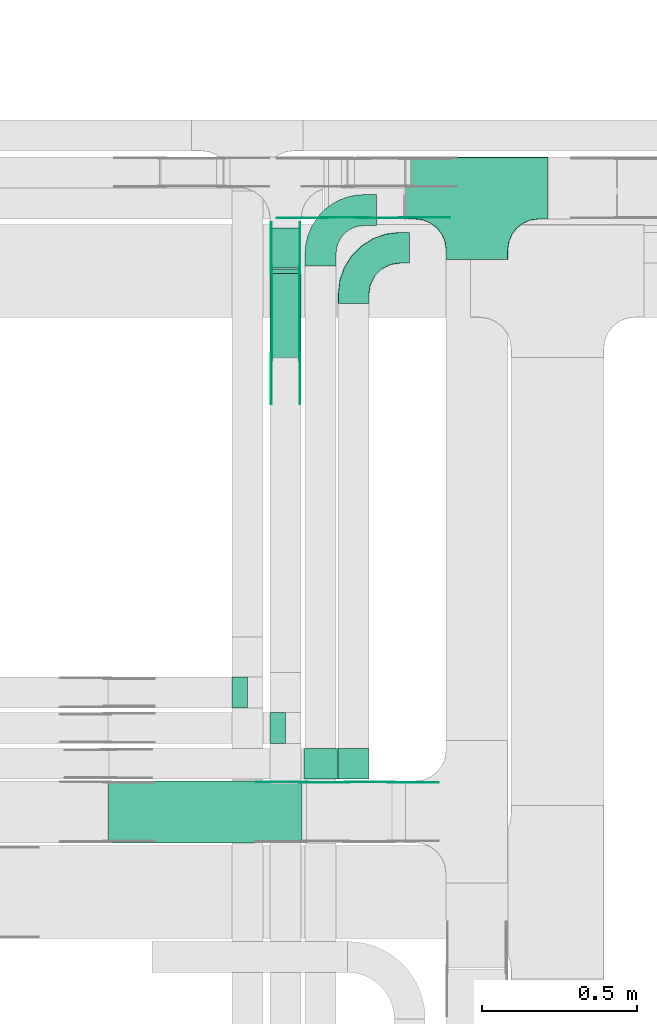
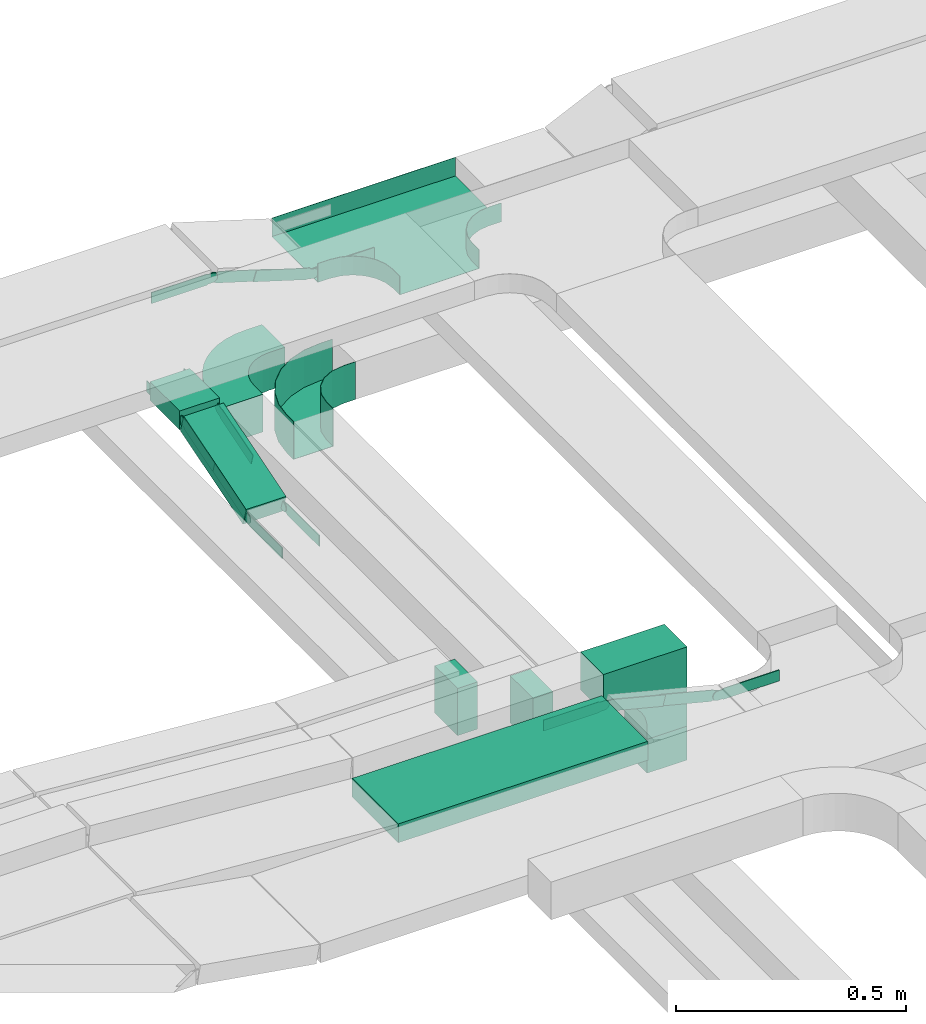
# One storey, part 6 of 19: 20 flow fittings, 6 flow segments.
"""IFC2X3 building model written with IfcOpenShell, lengths in millimetres."""

from ifc_helpers import new_model, entity, si_unit, converted_unit, derived_unit, direction, frame, frame_2d, origin, origin_2d_with_axis, place, context, subcontext, project, spatial, polyline, circle_curve, parameter, trimmed, segment, composite_curve, rectangle, outline, extrude, faceted_brep, source, transform, mapped, material, type_object, type_shapes, element, save


model = new_model("IFC2X3")

# Units and contexts
model_context = context("Model", 3, precision=0.01, world=origin(), true_north=direction((6.12303176911189e-17, 1.0)))
body_context = subcontext(model_context, "Body", "Model", "MODEL_VIEW")
ifc_project = project(units=[si_unit("LENGTHUNIT", "METRE", prefix="MILLI"), si_unit("AREAUNIT", "SQUARE_METRE"), si_unit("VOLUMEUNIT", "CUBIC_METRE"), converted_unit("PLANEANGLEUNIT", "DEGREE", entity("IfcRatioMeasure", 0.0174532925199433), si_unit("PLANEANGLEUNIT", "RADIAN"), dimensions=[0, 0, 0, 0, 0, 0, 0]), si_unit("MASSUNIT", "GRAM", prefix="KILO"), derived_unit("MASSDENSITYUNIT", [(si_unit("MASSUNIT", "GRAM", prefix="KILO"), 1), (si_unit("LENGTHUNIT", "METRE"), -3)]), derived_unit("MOMENTOFINERTIAUNIT", [(si_unit("LENGTHUNIT", "METRE"), 4)]), si_unit("TIMEUNIT", "SECOND"), si_unit("FREQUENCYUNIT", "HERTZ"), si_unit("THERMODYNAMICTEMPERATUREUNIT", "DEGREE_CELSIUS"), derived_unit("THERMALTRANSMITTANCEUNIT", [(si_unit("MASSUNIT", "GRAM", prefix="KILO"), 1), (si_unit("THERMODYNAMICTEMPERATUREUNIT", "KELVIN"), -1), (si_unit("TIMEUNIT", "SECOND"), -3)]), derived_unit("VOLUMETRICFLOWRATEUNIT", [(si_unit("LENGTHUNIT", "METRE"), 3), (si_unit("TIMEUNIT", "SECOND"), -1)]), derived_unit("MASSFLOWRATEUNIT", [(si_unit("MASSUNIT", "GRAM", prefix="KILO"), 1), (si_unit("TIMEUNIT", "SECOND"), -1)]), derived_unit("ROTATIONALFREQUENCYUNIT", [(si_unit("TIMEUNIT", "SECOND"), -1)]), si_unit("ELECTRICCURRENTUNIT", "AMPERE"), si_unit("ELECTRICVOLTAGEUNIT", "VOLT"), si_unit("POWERUNIT", "WATT"), si_unit("FORCEUNIT", "NEWTON", prefix="KILO"), si_unit("ILLUMINANCEUNIT", "LUX"), si_unit("LUMINOUSFLUXUNIT", "LUMEN"), si_unit("LUMINOUSINTENSITYUNIT", "CANDELA"), derived_unit("USERDEFINED", [(si_unit("MASSUNIT", "GRAM", prefix="KILO"), -1), (si_unit("LENGTHUNIT", "METRE"), -2), (si_unit("TIMEUNIT", "SECOND"), 3), (si_unit("LUMINOUSFLUXUNIT", "LUMEN"), 1)]), derived_unit("LINEARVELOCITYUNIT", [(si_unit("LENGTHUNIT", "METRE"), 1), (si_unit("TIMEUNIT", "SECOND"), -1)]), si_unit("PRESSUREUNIT", "PASCAL"), derived_unit("USERDEFINED", [(si_unit("LENGTHUNIT", "METRE"), -2), (si_unit("MASSUNIT", "GRAM", prefix="KILO"), 1), (si_unit("TIMEUNIT", "SECOND"), -2)]), derived_unit("LINEARFORCEUNIT", [(si_unit("MASSUNIT", "GRAM", prefix="KILO"), 1), (si_unit("LENGTHUNIT", "METRE"), 1), (si_unit("TIMEUNIT", "SECOND"), -2), (si_unit("LENGTHUNIT", "METRE"), -1)]), derived_unit("PLANARFORCEUNIT", [(si_unit("MASSUNIT", "GRAM", prefix="KILO"), 1), (si_unit("LENGTHUNIT", "METRE"), 1), (si_unit("TIMEUNIT", "SECOND"), -2), (si_unit("LENGTHUNIT", "METRE"), -2)])], contexts=[model_context])

# Site, building, storey
site_placement = place(None, frame((0.0, -0.00077364408347762, 0.0)))
site = spatial("IfcSite", under=ifc_project, at=site_placement, CompositionType="ELEMENT")
building_placement = place(site_placement, origin())
building = spatial("IfcBuilding", under=site, at=building_placement, CompositionType="ELEMENT")
storey_placement = place(building_placement, frame((0.0, 0.0, 12000.0)))
storey = spatial("IfcBuildingStorey", under=building, at=storey_placement, CompositionType="ELEMENT", Elevation=12000.0)

# Flow segments
cable_carrier_segment_type = type_object("IfcCableCarrierSegmentType", PredefinedType="CABLETRAYSEGMENT")
flow_segment_1_placement = place(storey_placement, frame((17450.8030725781, 14414.5228594546, 2586.13196287297)))
element("IfcFlowSegment", 1, at=flow_segment_1_placement, inside=storey, type_object=cable_carrier_segment_type, context=body_context, shape_type="SweptSolid", body=[
    extrude(rectangle(XDim=129.10701547123, YDim=99.9999999999989, at=frame_2d((1.08002495835535e-12, 0.0), x_axis=(1.0, 0.0))), frame((50.0, 64.5535077356138, 0.0), z_axis=(0.0, 0.0, 1.0), x_axis=(0.0, -1.0, 0.0)), (0.0, 0.0, 1.0), 50.0000000000016),
])
flow_segment_2_placement = place(storey_placement, frame((17327.7611527256, 12994.157206347, 2680.0)))
element("IfcFlowSegment", 2, at=flow_segment_2_placement, inside=storey, type_object=cable_carrier_segment_type, context=body_context, shape_type="SweptSolid", body=[
    extrude(rectangle(XDim=99.9999999999989, YDim=50.0000000000016, at=frame_2d((-2.16715534406831e-12, 2.16715534406831e-12), x_axis=(1.0, 0.0))), frame((25.0, 50.0, 0.0), z_axis=(0.0, 0.0, 1.0), x_axis=(0.0, 1.0, 0.0)), (0.0, 0.0, 1.0), 125.0),
])
flow_segment_3_placement = place(storey_placement, frame((17450.8030725781, 14125.2555366497, 2502.6519148827)))
element("IfcFlowSegment", 3, at=flow_segment_3_placement, inside=storey, type_object=cable_carrier_segment_type, context=body_context, shape_type="SweptSolid", body=[
    extrude(rectangle(XDim=49.9999999999967, YDim=283.929306322978, at=frame_2d((1.03739239420975e-12, -3.17967874252645e-13), x_axis=(0.0, 1.0))), frame((0.0, 143.070765615047, 65.4140665542328), z_axis=(1.0, 0.0, 0.0), x_axis=(0.0, -0.956304755963122, -0.292371704722454)), (0.0, 0.0, 1.0), 99.9999999999989),
])
flow_segment_4_placement = place(storey_placement, frame((17450.803072578, 12879.4401033081, 2680.0)))
element("IfcFlowSegment", 4, at=flow_segment_4_placement, inside=storey, type_object=cable_carrier_segment_type, context=body_context, shape_type="SweptSolid", body=[
    extrude(rectangle(XDim=99.9999999999989, YDim=50.0000000000016, at=frame_2d((0.0, -2.16715534406831e-12), x_axis=(1.0, 0.0))), frame((25.0, 50.0, 0.0), z_axis=(0.0, 0.0, 1.0), x_axis=(0.0, 1.0, 0.0)), (0.0, 0.0, 1.0), 125.0),
])
flow_segment_5_placement = place(storey_placement, frame((17670.2969319306, 12764.157206347, 2600.0)))
element("IfcFlowSegment", 5, at=flow_segment_5_placement, inside=storey, type_object=cable_carrier_segment_type, context=body_context, shape_type="SweptSolid", body=[
    extrude(rectangle(XDim=99.9999999999989, YDim=99.9999999999989, at=origin_2d_with_axis()), frame((50.0, 50.0, 0.0), z_axis=(0.0, 0.0, 1.0), x_axis=(-1.0, 0.0, 0.0)), (0.0, 0.0, 1.0), 90.000000000038),
])
flow_segment_6_placement = place(storey_placement, frame((16927.6135747369, 12558.7956510924, 2800.0)))
element("IfcFlowSegment", 6, at=flow_segment_6_placement, inside=storey, type_object=cable_carrier_segment_type, context=body_context, shape_type="SweptSolid", body=[
    extrude(rectangle(XDim=625.530791542038, YDim=199.999999999998, at=frame_2d((-1.08002495835535e-12, 0.0), x_axis=(1.0, 0.0))), frame((312.76539577102, 100.0, 0.0)), (0.0, 0.0, 1.0), 50.0000000000016),
])

# Flow fittings
ifc_material_1 = material(Name="G")
cable_carrier_fitting_type_1 = type_object("IfcCableCarrierFittingType", PredefinedType="NOTDEFINED", material=ifc_material_1)
shared_shape_1 = source(origin(), body_context, "Body", "SweptSolid", [
    extrude(outline(composite_curve([segment(trimmed(circle_curve(frame_2d((-44.5901162790698, 0.0), x_axis=(1.0, 0.0)), 12.5), [parameter(90.0000000000007)], [parameter(270.0)], True, "PARAMETER"), True, "CONTINUOUS"), segment(polyline([(-44.5901162790697, -12.5), (-33.0901162790698, -12.5)]), True, "CONTINUOUS"), segment(polyline([(-33.0901162790698, -12.5), (-31.2296511627907, -14.5)]), True, "CONTINUOUS"), segment(polyline([(-31.2296511627907, -14.5), (108.90988372093, -14.5)]), True, "CONTINUOUS"), segment(polyline([(108.90988372093, -14.5), (108.90988372093, 14.5)]), True, "CONTINUOUS"), segment(polyline([(108.90988372093, 14.5), (-31.2296511627907, 14.5)]), True, "CONTINUOUS"), segment(polyline([(-31.2296511627907, 14.5), (-33.0901162790698, 12.5)]), True, "CONTINUOUS"), segment(polyline([(-33.0901162790698, 12.5), (-44.5901162790699, 12.5)]), True, "CONTINUOUS")], self_intersect=False)), frame((44.5901162790698, 0.0, 0.0), z_axis=(0.0, 0.0, -1.0), x_axis=(1.0, 0.0, 0.0)), (0.0, 0.0, -1.0), 2.0),
])
type_shapes(cable_carrier_fitting_type_1, [shared_shape_1])
for number, where, z_axis, x_axis in (
    (7, (17626.2684992664, 14577.0367896898, 2830.26807837875), (0.0, -1.0, 0.0), (-1.0, 0.0, 0.0)),
    (8, (17455.3430725679, 14409.1887804155, 2611.13196287389), (-1.0, 0.0, 0.0), (0.0, 1.0, 0.0)),
    (9, (17455.3430725679, 14127.463824114, 2525.0), (-1.0, 0.0, 0.0), (0.0, -1.0, 0.0)),
    (10, (17841.1625871757, 12754.2556511025, 2752.85030390839), (0.0, 1.0, 0.0), (-0.969084530600981, 0.0, 0.246728945504732)),
):
    element("IfcFlowFitting", number, at=place(storey_placement, frame(where, z_axis=z_axis, x_axis=x_axis)), inside=storey, type_object=cable_carrier_fitting_type_1, material=ifc_material_1, context=body_context, shape_type="MappedRepresentation", body=[
        mapped(shared_shape_1, transform((0.0, 0.0, 0.0), scale=1.0)),
    ])
cable_carrier_fitting_type_2 = type_object("IfcCableCarrierFittingType", PredefinedType="NOTDEFINED", material=ifc_material_1)
shared_shape_2 = source(origin(), body_context, "Body", "SweptSolid", [
    extrude(outline(composite_curve([segment(trimmed(circle_curve(frame_2d((-44.5901162790697, 0.0), x_axis=(1.0, 0.0)), 12.5), [parameter(90.0000000000007)], [parameter(270.0)], True, "PARAMETER"), True, "CONTINUOUS"), segment(polyline([(-44.5901162790697, -12.5), (-33.0901162790697, -12.5)]), True, "CONTINUOUS"), segment(polyline([(-33.0901162790697, -12.5), (-31.2296511627907, -14.5)]), True, "CONTINUOUS"), segment(polyline([(-31.2296511627907, -14.5), (108.90988372093, -14.5)]), True, "CONTINUOUS"), segment(polyline([(108.90988372093, -14.5), (108.90988372093, 14.5)]), True, "CONTINUOUS"), segment(polyline([(108.90988372093, 14.5), (-31.2296511627907, 14.5)]), True, "CONTINUOUS"), segment(polyline([(-31.2296511627907, 14.5), (-33.0901162790698, 12.5)]), True, "CONTINUOUS"), segment(polyline([(-33.0901162790698, 12.5), (-44.5901162790699, 12.5)]), True, "CONTINUOUS")], self_intersect=False)), frame((44.5901162790697, 0.0, 0.0)), (0.0, 0.0, 1.0), 2.0),
])
type_shapes(cable_carrier_fitting_type_2, [shared_shape_2])
for number, where, z_axis, x_axis in (
    (11, (17879.4906296141, 14577.0367896898, 2752.85030390972), (0.0, -1.0, 0.0), (-0.956304755962822, 0.0, 0.292371704723434)),
    (12, (17546.2630725882, 14409.1887804155, 2611.13196287389), (1.0, 0.0, 0.0), (0.0, 1.0, 0.0)),
    (13, (17546.2630725882, 14127.463824114, 2525.0), (1.0, 0.0, 0.0), (0.0, -1.0, 0.0)),
    (14, (17557.7781053636, 12754.2556511025, 2825.0), (0.0, 1.0, 0.0), (-1.0, 0.0, 0.0)),
):
    element("IfcFlowFitting", number, at=place(storey_placement, frame(where, z_axis=z_axis, x_axis=x_axis)), inside=storey, type_object=cable_carrier_fitting_type_2, material=ifc_material_1, context=body_context, shape_type="MappedRepresentation", body=[
        mapped(shared_shape_2, transform((0.0, 0.0, 0.0), scale=1.0)),
    ])
cable_carrier_fitting_type_3 = type_object("IfcCableCarrierFittingType", PredefinedType="NOTDEFINED", material=ifc_material_1)
shared_shape_3 = source(origin(), body_context, "Body", "SweptSolid", [
    extrude(outline(composite_curve([segment(trimmed(circle_curve(frame_2d((-44.5901162790698, 0.0), x_axis=(1.0, 0.0)), 12.5), [parameter(90.0000000000007)], [parameter(270.0)], True, "PARAMETER"), True, "CONTINUOUS"), segment(polyline([(-44.5901162790697, -12.5), (-33.0901162790698, -12.5)]), True, "CONTINUOUS"), segment(polyline([(-33.0901162790698, -12.5), (-31.2296511627907, -14.5)]), True, "CONTINUOUS"), segment(polyline([(-31.2296511627907, -14.5), (108.90988372093, -14.5)]), True, "CONTINUOUS"), segment(polyline([(108.90988372093, -14.5), (108.90988372093, 14.5)]), True, "CONTINUOUS"), segment(polyline([(108.90988372093, 14.5), (-31.2296511627907, 14.5)]), True, "CONTINUOUS"), segment(polyline([(-31.2296511627907, 14.5), (-33.0901162790698, 12.5)]), True, "CONTINUOUS"), segment(polyline([(-33.0901162790698, 12.5), (-44.5901162790699, 12.5)]), True, "CONTINUOUS")], self_intersect=False)), frame((44.5901162790698, 0.0, 0.0), z_axis=(0.0, 0.0, -1.0), x_axis=(1.0, 0.0, 0.0)), (0.0, 0.0, -1.0), 2.0),
])
type_shapes(cable_carrier_fitting_type_3, [shared_shape_3])
for number, where, z_axis, x_axis in (
    (15, (17879.4906296141, 14579.0367896898, 2752.85030390973), (0.0, -1.0, 0.0), (1.0, 0.0, 0.0)),
    (16, (17544.2630725882, 14409.1887804156, 2611.13196287389), (1.0, 0.0, 0.0), (0.0, -0.956304755963097, -0.292371704722536)),
    (17, (17544.2630725882, 14127.463824114, 2525.0), (1.0, 0.0, 0.0), (0.0, 0.956304755963132, 0.292371704722421)),
    (18, (17557.7781053635, 12752.2556511025, 2825.0), (0.0, 1.0, 0.0), (0.96908453060098, 0.0, -0.246728945504733)),
):
    element("IfcFlowFitting", number, at=place(storey_placement, frame(where, z_axis=z_axis, x_axis=x_axis)), inside=storey, type_object=cable_carrier_fitting_type_3, material=ifc_material_1, context=body_context, shape_type="MappedRepresentation", body=[
        mapped(shared_shape_3, transform((0.0, 0.0, 0.0), scale=1.0)),
    ])
cable_carrier_fitting_type_4 = type_object("IfcCableCarrierFittingType", PredefinedType="NOTDEFINED", material=ifc_material_1)
shared_shape_4 = source(origin(), body_context, "Body", "SweptSolid", [
    extrude(outline(composite_curve([segment(trimmed(circle_curve(frame_2d((-44.5901162790697, 0.0), x_axis=(1.0, 0.0)), 12.5), [parameter(90.0000000000007)], [parameter(270.0)], True, "PARAMETER"), True, "CONTINUOUS"), segment(polyline([(-44.5901162790697, -12.5), (-33.0901162790697, -12.5)]), True, "CONTINUOUS"), segment(polyline([(-33.0901162790697, -12.5), (-31.2296511627907, -14.5)]), True, "CONTINUOUS"), segment(polyline([(-31.2296511627907, -14.5), (108.90988372093, -14.5)]), True, "CONTINUOUS"), segment(polyline([(108.90988372093, -14.5), (108.90988372093, 14.5)]), True, "CONTINUOUS"), segment(polyline([(108.90988372093, 14.5), (-31.2296511627907, 14.5)]), True, "CONTINUOUS"), segment(polyline([(-31.2296511627907, 14.5), (-33.0901162790698, 12.5)]), True, "CONTINUOUS"), segment(polyline([(-33.0901162790698, 12.5), (-44.5901162790699, 12.5)]), True, "CONTINUOUS")], self_intersect=False)), frame((44.5901162790697, 0.0, 0.0)), (0.0, 0.0, 1.0), 2.0),
])
type_shapes(cable_carrier_fitting_type_4, [shared_shape_4])
for number, where, z_axis, x_axis in (
    (19, (17626.2684992664, 14579.0367896899, 2830.26807837874), (0.0, -1.0, 0.0), (0.956304755964475, 0.0, -0.29237170471803)),
    (20, (17457.3430725679, 14409.1887804156, 2611.13196287389), (-1.0, 0.0, 0.0), (0.0, -0.956304755963097, -0.292371704722536)),
    (21, (17457.3430725679, 14127.463824114, 2525.0), (-1.0, 0.0, 0.0), (0.0, 0.956304755963132, 0.292371704722421)),
    (22, (17841.1625871757, 12752.2556511025, 2752.85030390839), (0.0, 1.0, 0.0), (1.0, 0.0, 0.0)),
):
    element("IfcFlowFitting", number, at=place(storey_placement, frame(where, z_axis=z_axis, x_axis=x_axis)), inside=storey, type_object=cable_carrier_fitting_type_4, material=ifc_material_1, context=body_context, shape_type="MappedRepresentation", body=[
        mapped(shared_shape_4, transform((0.0, 0.0, 0.0), scale=1.0)),
    ])
ifc_material_2 = material()
cable_carrier_fitting_type_5 = type_object("IfcCableCarrierFittingType", PredefinedType="NOTDEFINED", material=ifc_material_2)
shared_shape_5 = source(origin(), body_context, "Body", "Brep", [
    faceted_brep([(-103.407417371087, -174.118095489753, 25.0), (-100.0, -200.0, 25.0), (-100.0, -230.0, 25.0), (-99.1999999999932, -230.0, 25.0), (-99.1999999999933, -200.0, 25.0), (-102.634676710055, -173.911040253671, 25.0), (-112.704639298522, -149.600000000004, 25.0), (-128.723636456391, -128.7236364564, 25.0), (-149.599999999996, -112.704639298532, 25.0), (-173.911040253663, -102.634676710066, 25.0), (-200.0, -99.2000000000044, 25.0), (-230.0, -99.2000000000044, 25.0), (-230.0, -100.0, 25.0), (-200.0, -100.0, 25.0), (-174.118095489746, -103.407417371099, 25.0), (-150.0, -113.397459621561, 25.0), (-129.28932188134, -129.28932188135, 25.0), (-113.39745962155, -150.0, 25.0), (230.0, -100.0, 25.0), (230.0, -99.2000000000044, 25.0), (200.0, -99.2000000000097, 25.0), (173.911040253722, -102.634676710071, 25.0), (149.60000000005, -112.704639298537, 25.0), (128.723636456439, -128.723636456403, 25.0), (112.704639298563, -149.600000000006, 25.0), (102.634676710086, -173.911040253673, 25.0), (99.2000000000121, -200.0, 25.0), (99.2000000000069, -230.0, 25.0), (100.0, -230.0, 25.0), (100.0, -200.0, 25.0), (103.407417371119, -174.118095489755, 25.0), (113.397459621593, -150.0, 25.0), (129.289321881391, -129.289321881354, 25.0), (150.0, -113.397459621567, 25.0), (174.118095489805, -103.407417371105, 25.0), (200.0, -100.0, 25.0), (230.0, 99.1999999999954, 25.0), (230.0, 100.0, 25.0), (-230.0, 100.0, 25.0), (-230.0, 99.1999999999954, 25.0), (-230.0, -100.0, -25.0), (-230.0, 100.0, -25.0), (230.0, 100.0, -25.0), (230.0, -100.0, -25.0), (200.0, -100.0, -25.0), (174.118095489805, -103.407417371105, -25.0), (150.0, -113.397459621567, -25.0), (129.289321881391, -129.289321881354, -25.0), (113.397459621593, -150.0, -25.0), (103.407417371119, -174.118095489755, -25.0), (100.0, -200.0, -25.0), (100.0, -230.0, -25.0), (-100.0, -230.0, -25.0), (-100.0, -200.0, -25.0), (-103.407417371087, -174.118095489753, -25.0), (-113.39745962155, -150.0, -25.0), (-129.28932188134, -129.28932188135, -25.0), (-150.0, -113.397459621561, -25.0), (-174.118095489746, -103.407417371099, -25.0), (-200.0, -100.0, -25.0), (-100.0, -200.0, -24.199999999986), (99.2000000000069, -230.0, -24.199999999986), (-99.1999999999932, -230.0, -24.199999999986), (-99.1999999999933, -200.0, -24.199999999986), (-200.0, -99.2000000000044, -24.199999999986), (-230.0, -99.2000000000044, -24.199999999986), (230.0, -99.2000000000044, -24.199999999986), (200.0, -99.2000000000044, -24.199999999986), (-230.0, 99.1999999999954, -24.199999999986), (-200.0, -100.0, -24.199999999986), (200.0, -100.0, -24.199999999986), (230.0, 99.1999999999954, -24.199999999986), (99.2000000000121, -200.0, -24.199999999986), (100.0, -200.0, -24.199999999986), (-173.911040253663, -102.634676710066, -24.199999999986), (-149.599999999996, -112.704639298532, -24.199999999986), (-128.723636456391, -128.7236364564, -24.199999999986), (-112.704639298522, -149.600000000004, -24.199999999986), (-102.634676710055, -173.911040253671, -24.199999999986), (102.634676710086, -173.911040253674, -24.199999999986), (112.704639298563, -149.600000000007, -24.199999999986), (128.723636456439, -128.723636456403, -24.199999999986), (149.60000000005, -112.704639298537, -24.199999999986), (173.911040253721, -102.634676710071, -24.199999999986)], [[[0, 1, 2, 3, 4, 5, 6, 7, 8, 9, 10, 11, 12, 13, 14, 15, 16, 17]], [[18, 19, 20, 21, 22, 23, 24, 25, 26, 27, 28, 29, 30, 31, 32, 33, 34, 35]], [[36, 37, 38, 39]], [[40, 41, 42, 43, 44, 45, 46, 47, 48, 49, 50, 51, 52, 53, 54, 55, 56, 57, 58, 59]], [[2, 1, 60, 53, 52]], [[3, 2, 52, 51, 28, 27, 61, 62]], [[4, 3, 62, 63]], [[11, 10, 64, 65]], [[20, 19, 66, 67]], [[39, 38, 41, 40, 12, 11, 65, 68]], [[13, 12, 40, 59, 69]], [[18, 35, 70, 44, 43]], [[19, 18, 43, 42, 37, 36, 71, 66]], [[27, 26, 72, 61]], [[29, 28, 51, 50, 73]], [[38, 37, 42, 41]], [[36, 39, 68, 71]], [[68, 65, 64, 74, 75, 76, 77, 78, 63, 62, 61, 72, 79, 80, 81, 82, 83, 67, 66, 71]], [[14, 13, 69, 59, 58]], [[58, 57, 15, 14]], [[15, 57, 56, 16]], [[0, 17, 55, 54]], [[0, 54, 53, 60, 1]], [[55, 17, 16, 56]], [[5, 4, 63, 78]], [[6, 5, 78, 77]], [[7, 6, 77, 76]], [[8, 7, 76, 75]], [[9, 8, 75, 74]], [[10, 9, 74, 64]], [[21, 20, 67, 83]], [[22, 21, 83, 82]], [[23, 22, 82, 81]], [[81, 80, 24, 23]], [[24, 80, 79, 25]], [[79, 72, 26, 25]], [[30, 29, 73, 50, 49]], [[31, 30, 49, 48]], [[31, 48, 47, 32]], [[33, 32, 47, 46]], [[45, 34, 33, 46]], [[34, 45, 44, 70, 35]]]),
])
type_shapes(cable_carrier_fitting_type_5, [shared_shape_5])
flow_fitting_1_placement = place(storey_placement, frame((18118.5874268759, 14672.4967897, 2752.85030390974)))
element("IfcFlowFitting", 23, at=flow_fitting_1_placement, inside=storey, type_object=cable_carrier_fitting_type_5, material=ifc_material_2, Name="470_DKC_S5_T", context=body_context, shape_type="MappedRepresentation", body=[
    mapped(shared_shape_5, transform((0.0, 0.0, 0.0), scale=1.0)),
])
cable_carrier_fitting_type_6 = type_object("IfcCableCarrierFittingType", Name="470_DKC_S5_CPO 45 horizontal angle:-", PredefinedType="NOTDEFINED", material=ifc_material_2)
shared_shape_6 = source(origin(), body_context, "Body", "Brep", [
    faceted_brep([(-180.0, -49.2000000000082, -49.2000000000019), (-180.0, 49.1999999999917, -49.2000000000019), (-180.0, 49.1999999999917, 50.0), (-180.0, 50.0, 50.0), (-180.0, 50.0, -50.0), (-180.0, -50.0, -50.0), (-180.0, -50.0, 50.0), (-180.0, -49.2000000000082, 50.0), (-150.0, -50.0, -50.0), (-150.0, -50.0, 50.0), (-105.495813208728, -44.9855824363732, 50.0), (-63.2232521764796, -30.1937735804923, 50.0), (-25.3020396282445, -6.36629649361443, 50.0), (6.3662964936147, 25.3020396282448, 50.0), (30.1937735804926, 63.2232521764798, 50.0), (44.9855824363735, 105.495813208729, 50.0), (50.0, 150.0, 50.0), (50.0, 180.0, 50.0), (49.2000000000087, 180.0, 50.0), (49.2000000000086, 150.0, 50.0), (44.2056401066279, 105.673829955894, 50.0), (29.4729984861705, 63.5703591677739, 50.0), (5.74083130764015, 25.8008314697319, 50.0), (-25.8008314697316, -5.74083130763988, 50.0), (-63.5703591677737, -29.4729984861702, 50.0), (-105.673829955893, -44.2056401066275, 50.0), (-150.0, -49.2000000000082, 50.0), (-150.0, 49.1999999999917, 50.0), (-118.851086966997, 54.1335031574402, 50.0), (-90.75124656891, 68.451086966997, 50.0), (-68.4510869669966, 90.7512465689103, 50.0), (-54.1335031574399, 118.851086966997, 50.0), (-49.1999999999913, 150.0, 50.0), (-49.1999999999912, 180.0, 50.0), (-50.0, 180.0, 50.0), (-50.0, 150.0, 50.0), (-54.8943483704758, 119.098300562497, 50.0), (-69.0983005624964, 91.2214747707442, 50.0), (-91.2214747707439, 69.0983005624968, 50.0), (-119.098300562496, 54.8943483704762, 50.0), (-150.0, 50.0, 50.0), (-150.0, -49.2000000000082, -49.2000000000019), (-105.673829955893, -44.2056401066275, -49.2000000000019), (-63.5703591677737, -29.4729984861702, -49.2000000000019), (-25.8008314697316, -5.74083130763988, -49.2000000000019), (5.74083130764015, 25.8008314697319, -49.2000000000019), (29.4729984861705, 63.5703591677739, -49.2000000000019), (44.2056401066279, 105.673829955894, -49.2000000000019), (49.2000000000087, 150.0, -49.2000000000019), (49.2000000000087, 180.0, -49.2000000000019), (-49.1999999999912, 180.0, -49.2000000000019), (-49.1999999999913, 150.0, -49.2000000000019), (-54.1335031574399, 118.851086966997, -49.2000000000019), (-68.4510869669966, 90.7512465689103, -49.2000000000019), (-90.75124656891, 68.451086966997, -49.2000000000019), (-118.851086966997, 54.1335031574402, -49.2000000000019), (-150.0, 49.1999999999917, -49.2000000000019), (-150.0, 50.0, -50.0), (-119.098300562496, 54.8943483704762, -50.0), (-91.2214747707439, 69.0983005624968, -50.0), (-69.0983005624964, 91.2214747707442, -50.0), (-54.8943483704758, 119.098300562497, -50.0), (-50.0, 150.0, -50.0), (-50.0, 180.0, -50.0), (50.0, 180.0, -50.0), (50.0, 150.0, -50.0), (44.9855824363735, 105.495813208729, -50.0), (30.1937735804926, 63.2232521764798, -50.0), (6.3662964936147, 25.3020396282448, -50.0), (-25.3020396282445, -6.36629649361443, -50.0), (-63.2232521764796, -30.1937735804923, -50.0), (-105.495813208728, -44.9855824363732, -50.0)], [[[0, 1, 2, 3, 4, 5, 6, 7]], [[6, 5, 8, 9]], [[7, 6, 9, 10, 11, 12, 13, 14, 15, 16, 17, 18, 19, 20, 21, 22, 23, 24, 25, 26]], [[3, 2, 27, 28, 29, 30, 31, 32, 33, 34, 35, 36, 37, 38, 39, 40]], [[0, 7, 26, 41]], [[1, 0, 41, 42, 43, 44, 45, 46, 47, 48, 49, 50, 51, 52, 53, 54, 55, 56]], [[2, 1, 56, 27]], [[4, 3, 40, 57]], [[57, 58, 59, 60, 61, 62, 63, 64, 65, 66, 67, 68, 69, 70, 71, 8, 5, 4]], [[10, 9, 8, 71]], [[71, 70, 11, 10]], [[69, 12, 11, 70]], [[69, 68, 13, 12]], [[13, 68, 67, 14]], [[14, 67, 66, 15]], [[15, 66, 65, 16]], [[42, 41, 26, 25]], [[24, 43, 42, 25]], [[43, 24, 23, 44]], [[23, 22, 45, 44]], [[46, 45, 22, 21]], [[47, 46, 21, 20]], [[48, 47, 20, 19]], [[55, 54, 29, 28]], [[56, 55, 28, 27]], [[54, 53, 30, 29]], [[30, 53, 52, 31]], [[31, 52, 51, 32]], [[39, 38, 59, 58]], [[39, 58, 57, 40]], [[38, 37, 60, 59]], [[61, 60, 37, 36]], [[62, 61, 36, 35]], [[63, 34, 33, 50, 49, 18, 17, 64]], [[16, 65, 64, 17]], [[48, 19, 18, 49]], [[32, 51, 50, 33]], [[62, 35, 34, 63]]]),
])
type_shapes(cable_carrier_fitting_type_6, [shared_shape_6])
flow_fitting_2_placement = place(storey_placement, frame((17720.2969319306, 14479.9939090693, 2550.0), z_axis=(-1.54615696088747e-06, 0.0, 1.0), x_axis=(-1.0, 0.0, -1.54615696088747e-06)))
element("IfcFlowFitting", 24, at=flow_fitting_2_placement, inside=storey, type_object=cable_carrier_fitting_type_6, material=ifc_material_2, Name="470_DKC_S5_45 horizontal angle", ObjectType="470_DKC_S5_CPO 45 horizontal angle:-", context=body_context, shape_type="MappedRepresentation", body=[
    mapped(shared_shape_6, transform((0.0, 0.0, 0.0), scale=1.0)),
])
cable_carrier_fitting_type_7 = type_object("IfcCableCarrierFittingType", Name="470_DKC_S5_CD 90 external vertical angle:-", PredefinedType="NOTDEFINED", material=ifc_material_2)
shared_shape_7 = source(origin(), body_context, "Body", "SweptSolid", [
    extrude(outline(composite_curve([segment(polyline([(-100.0, -130.0), (-60.0, -130.0)]), True, "CONTINUOUS"), segment(trimmed(circle_curve(frame_2d((-60.0, 60.0), x_axis=(0.0, -1.0)), 189.999999999999), [parameter(0.0)], [parameter(90.0)], True, "PARAMETER"), True, "CONTINUOUS"), segment(polyline([(130.0, 60.0), (130.0, 100.0)]), True, "CONTINUOUS"), segment(polyline([(130.0, 100.0), (30.0, 100.0)]), True, "CONTINUOUS"), segment(polyline([(30.0, 100.0), (30.0, 60.0)]), True, "CONTINUOUS"), segment(trimmed(circle_curve(frame_2d((-60.0, 60.0), x_axis=(0.0, -1.0)), 89.9999999999988), [parameter(0.0)], [parameter(90.0)], True, "PARAMETER"), False, "CONTINUOUS"), segment(polyline([(-60.0, -30.0), (-100.0, -30.0)]), True, "CONTINUOUS"), segment(polyline([(-100.0, -30.0), (-100.0, -130.0)]), True, "CONTINUOUS")], self_intersect=False)), frame((-80.0, 80.0, -50.0)), (0.0, 0.0, 1.0), 99.9999999999999),
])
type_shapes(cable_carrier_fitting_type_7, [shared_shape_7])
flow_fitting_3_placement = place(storey_placement, frame((17613.8576040855, 14601.4220205216, 2552.0438798883), z_axis=(0.000377553037564522, -0.000472682466877915, 0.999999817012478), x_axis=(-0.999999928726833, 0.0, 0.000377553079742624)))
element("IfcFlowFitting", 25, at=flow_fitting_3_placement, inside=storey, type_object=cable_carrier_fitting_type_7, material=ifc_material_2, Name="470_DKC_S5_CD 90 external vertical angle:-", ObjectType="470_DKC_S5_CD 90 external vertical angle:-", context=body_context, shape_type="MappedRepresentation", body=[
    mapped(shared_shape_7, transform((0.0, 0.0, 0.0), scale=1.0)),
])
cable_carrier_fitting_type_8 = type_object("IfcCableCarrierFittingType", Name="470_DKC_S5_CDV 90 external vertical angle:-", PredefinedType="NOTDEFINED", material=ifc_material_2)
shared_shape_8 = source(origin(), body_context, "Body", "SweptSolid", [
    extrude(outline(composite_curve([segment(polyline([(65.7142857142854, 14.2857142857149), (95.7142857142855, 14.2857142857149)]), True, "CONTINUOUS"), segment(polyline([(95.7142857142855, 14.2857142857149), (95.7142857142855, 114.285714285713)]), True, "CONTINUOUS"), segment(polyline([(95.7142857142855, 114.285714285713), (-114.285714285714, 114.285714285713)]), True, "CONTINUOUS"), segment(polyline([(-114.285714285714, 114.285714285713), (-114.285714285714, -95.7142857142853)]), True, "CONTINUOUS"), segment(polyline([(-114.285714285714, -95.7142857142853), (-14.2857142857144, -95.7142857142853)]), True, "CONTINUOUS"), segment(polyline([(-14.2857142857145, -95.7142857142853), (-14.2857142857145, -65.7142857142849)]), True, "CONTINUOUS"), segment(trimmed(circle_curve(frame_2d((65.7142857142855, -65.714285714285), x_axis=(-1.0, 0.0)), 80.0), [parameter(270.0)], [parameter(2.54444374517082e-13)], True, "PARAMETER"), False, "CONTINUOUS")], self_intersect=False)), frame((-64.2857142857073, 64.2857142857068, -49.0), z_axis=(0.0, 0.0, 1.0), x_axis=(-1.0, 0.0, 0.0)), (0.0, 0.0, 1.0), 99.0000000000002),
])
type_shapes(cable_carrier_fitting_type_8, [shared_shape_8])
flow_fitting_4_placement = place(storey_placement, frame((17720.2969319306, 12814.157206347, 2850.0), z_axis=(0.0, -1.0, 0.0), x_axis=(0.0, 0.0, 1.0)))
element("IfcFlowFitting", 26, at=flow_fitting_4_placement, inside=storey, type_object=cable_carrier_fitting_type_8, material=ifc_material_2, Name="470_DKC_S5_90 external vertical angle", ObjectType="470_DKC_S5_CDV 90 external vertical angle:-", context=body_context, shape_type="MappedRepresentation", body=[
    mapped(shared_shape_8, transform((0.0, 0.0, 0.0), scale=1.0)),
])

save(model, "model.ifc")
